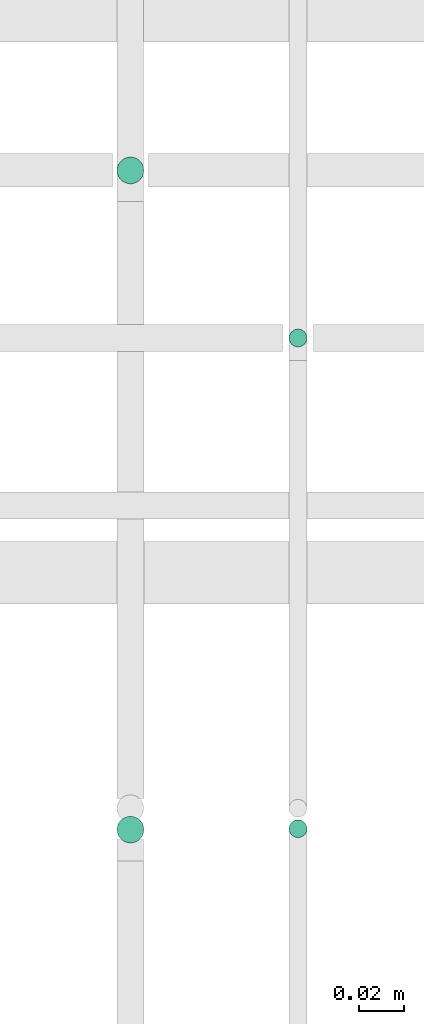
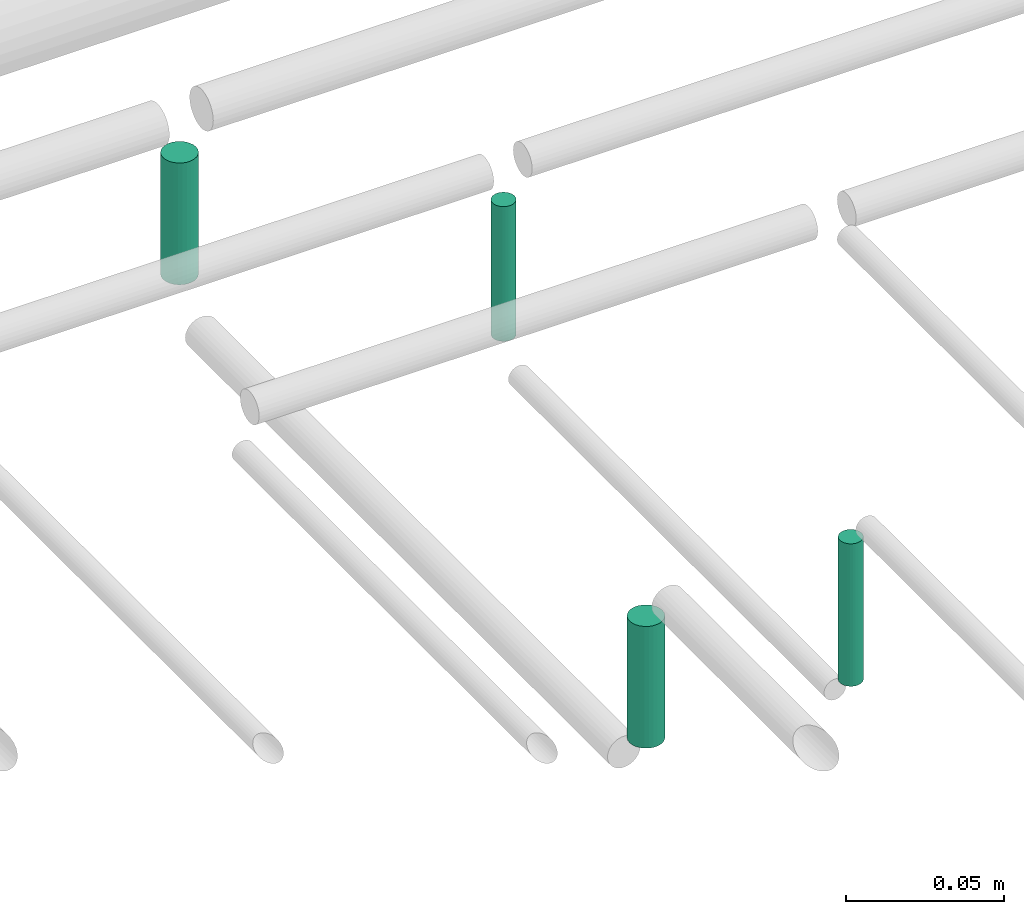
# One storey, part 278 of 331: 4 flow segments.
"""IFC2X3 building model written with IfcOpenShell, lengths in millimetres."""

from ifc_helpers import new_model, entity, si_unit, converted_unit, derived_unit, direction, frame, frame_2d, origin, origin_2d_with_axis, place, context, subcontext, project, spatial, circle, extrude, type_object, element, save


model = new_model("IFC2X3")

# Units and contexts
model_context = context("Model", 3, precision=0.01, world=origin(), true_north=direction((6.12303176911189e-17, 1.0)))
body_context = subcontext(model_context, "Body", "Model", "MODEL_VIEW")
ifc_project = project(units=[si_unit("LENGTHUNIT", "METRE", prefix="MILLI"), si_unit("AREAUNIT", "SQUARE_METRE"), si_unit("VOLUMEUNIT", "CUBIC_METRE"), converted_unit("PLANEANGLEUNIT", "DEGREE", entity("IfcRatioMeasure", 0.0174532925199433), si_unit("PLANEANGLEUNIT", "RADIAN"), dimensions=[0, 0, 0, 0, 0, 0, 0]), si_unit("MASSUNIT", "GRAM", prefix="KILO"), derived_unit("MASSDENSITYUNIT", [(si_unit("MASSUNIT", "GRAM", prefix="KILO"), 1), (si_unit("LENGTHUNIT", "METRE"), -3)]), derived_unit("MOMENTOFINERTIAUNIT", [(si_unit("LENGTHUNIT", "METRE"), 4)]), si_unit("TIMEUNIT", "SECOND"), si_unit("FREQUENCYUNIT", "HERTZ"), si_unit("THERMODYNAMICTEMPERATUREUNIT", "DEGREE_CELSIUS"), derived_unit("THERMALTRANSMITTANCEUNIT", [(si_unit("MASSUNIT", "GRAM", prefix="KILO"), 1), (si_unit("THERMODYNAMICTEMPERATUREUNIT", "KELVIN"), -1), (si_unit("TIMEUNIT", "SECOND"), -3)]), derived_unit("VOLUMETRICFLOWRATEUNIT", [(si_unit("LENGTHUNIT", "METRE"), 3), (si_unit("TIMEUNIT", "SECOND"), -1)]), derived_unit("MASSFLOWRATEUNIT", [(si_unit("MASSUNIT", "GRAM", prefix="KILO"), 1), (si_unit("TIMEUNIT", "SECOND"), -1)]), derived_unit("ROTATIONALFREQUENCYUNIT", [(si_unit("TIMEUNIT", "SECOND"), -1)]), si_unit("ELECTRICCURRENTUNIT", "AMPERE"), si_unit("ELECTRICVOLTAGEUNIT", "VOLT"), si_unit("POWERUNIT", "WATT"), si_unit("FORCEUNIT", "NEWTON", prefix="KILO"), si_unit("ILLUMINANCEUNIT", "LUX"), si_unit("LUMINOUSFLUXUNIT", "LUMEN"), si_unit("LUMINOUSINTENSITYUNIT", "CANDELA"), derived_unit("USERDEFINED", [(si_unit("MASSUNIT", "GRAM", prefix="KILO"), -1), (si_unit("LENGTHUNIT", "METRE"), -2), (si_unit("TIMEUNIT", "SECOND"), 3), (si_unit("LUMINOUSFLUXUNIT", "LUMEN"), 1)]), derived_unit("LINEARVELOCITYUNIT", [(si_unit("LENGTHUNIT", "METRE"), 1), (si_unit("TIMEUNIT", "SECOND"), -1)]), si_unit("PRESSUREUNIT", "PASCAL"), derived_unit("USERDEFINED", [(si_unit("LENGTHUNIT", "METRE"), -2), (si_unit("MASSUNIT", "GRAM", prefix="KILO"), 1), (si_unit("TIMEUNIT", "SECOND"), -2)]), derived_unit("LINEARFORCEUNIT", [(si_unit("MASSUNIT", "GRAM", prefix="KILO"), 1), (si_unit("LENGTHUNIT", "METRE"), 1), (si_unit("TIMEUNIT", "SECOND"), -2), (si_unit("LENGTHUNIT", "METRE"), -1)]), derived_unit("PLANARFORCEUNIT", [(si_unit("MASSUNIT", "GRAM", prefix="KILO"), 1), (si_unit("LENGTHUNIT", "METRE"), 1), (si_unit("TIMEUNIT", "SECOND"), -2), (si_unit("LENGTHUNIT", "METRE"), -2)])], contexts=[model_context])

# Site, building, storey
site_placement = place(None, frame((0.0, -0.00077364408347762, 0.0)))
site = spatial("IfcSite", under=ifc_project, at=site_placement, CompositionType="ELEMENT")
building_placement = place(site_placement, origin())
building = spatial("IfcBuilding", under=site, at=building_placement, CompositionType="ELEMENT")
storey_placement = place(building_placement, origin())
storey = spatial("IfcBuildingStorey", under=building, at=storey_placement, CompositionType="ELEMENT", Elevation=0.0)

# Flow segments
pipe_segment_type = type_object("IfcPipeSegmentType", PredefinedType="NOTDEFINED")
flow_segment_1_placement = place(storey_placement, frame((44789.6371022652, 8075.4146716134, 14485.0)))
element("IfcFlowSegment", 1, at=flow_segment_1_placement, inside=storey, type_object=pipe_segment_type, context=body_context, shape_type="SweptSolid", body=[
    extrude(circle(Radius=4.0, at=frame_2d((0.0, 1.08286712929839e-12), x_axis=(1.0, 0.0))), frame((5.59527223591499, 5.59527223591716, 0.0), z_axis=(0.0, 0.0, 1.0), x_axis=(-1.0, 0.0, 0.0)), (0.0, 0.0, 1.0), 55.0000000000178),
])
flow_segment_2_placement = place(storey_placement, frame((44712.6371022652, 8073.02529159144, 14489.0)))
element("IfcFlowSegment", 2, at=flow_segment_2_placement, inside=storey, type_object=pipe_segment_type, context=body_context, shape_type="SweptSolid", body=[
    extrude(circle(Radius=6.0, at=origin_2d_with_axis()), frame((7.59527223591454, 7.59527223591562, 0.0), z_axis=(0.0, 0.0, 1.0), x_axis=(-1.0, 0.0, 0.0)), (0.0, 0.0, 1.0), 47.0000000000196),
])
flow_segment_3_placement = place(storey_placement, frame((44789.6355109133, 8295.02529159145, 14484.999875164)))
element("IfcFlowSegment", 3, at=flow_segment_3_placement, inside=storey, type_object=pipe_segment_type, context=body_context, shape_type="SweptSolid", body=[
    extrude(circle(Radius=4.0, at=origin_2d_with_axis()), frame((5.59689508016131, 5.59527223591607, 0.000124835941699075)), (0.0, 0.0, 1.0), 51.9993258296599),
])
flow_segment_4_placement = place(storey_placement, frame((44712.6355353809, 8368.02529159144, 14488.9997934294)))
element("IfcFlowSegment", 4, at=flow_segment_4_placement, inside=storey, type_object=pipe_segment_type, context=body_context, shape_type="SweptSolid", body=[
    extrude(circle(Radius=6.0, at=frame_2d((0.0, 1.08286712929839e-12), x_axis=(1.0, 0.0))), frame((7.59689033834634, 7.59527223591454, 0.000206570451581456)), (0.0, 0.0, 1.0), 46.9991517581929),
])

save(model, "model.ifc")
